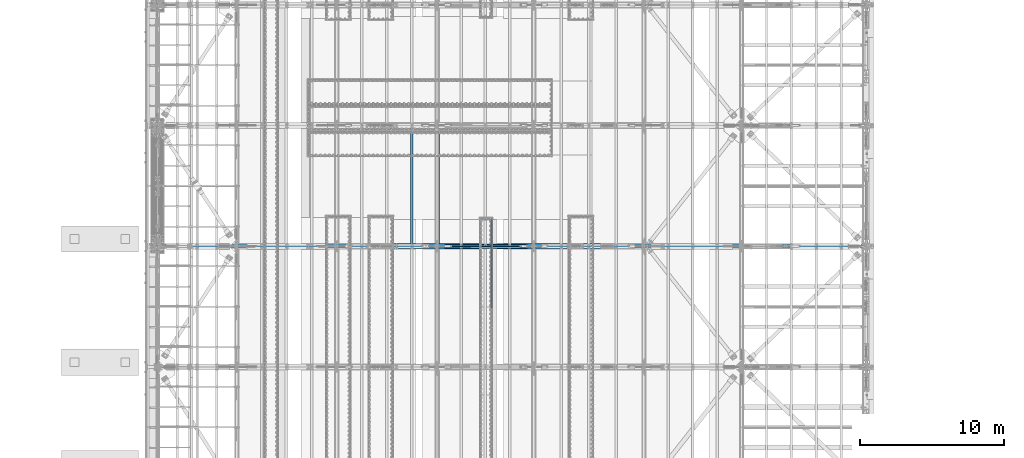
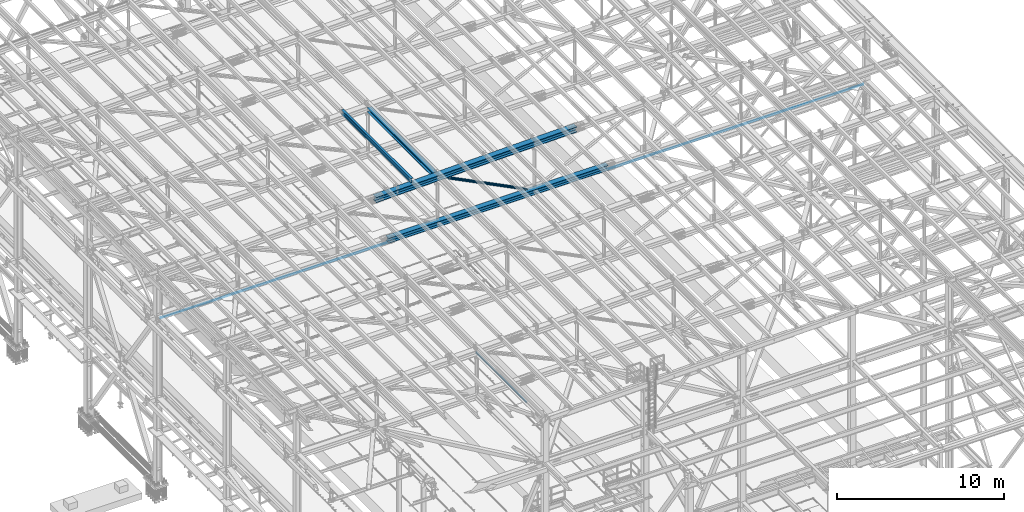
# One storey, part 1846 of 3843: 6 beams, 2 members, 8 elements without a shape of their own.
"""IFC2X3 building model written with IfcOpenShell, lengths in millimetres."""

from ifc_helpers import new_model, si_unit, frame, origin_with_axes, place, context, subcontext, project, spatial, faceted_brep, material, type_object, element, aggregate, save


model = new_model("IFC2X3")

# Units and contexts
model_context = context("Model", 3, precision=1e-05, world=origin_with_axes())
body_context = subcontext(model_context, "Body", "Model", "MODEL_VIEW")
ifc_project = project(units=[si_unit("LENGTHUNIT", "METRE", prefix="MILLI"), si_unit("AREAUNIT", "SQUARE_METRE"), si_unit("VOLUMEUNIT", "CUBIC_METRE"), si_unit("MASSUNIT", "GRAM", prefix="KILO"), si_unit("TIMEUNIT", "SECOND"), si_unit("PLANEANGLEUNIT", "RADIAN"), si_unit("SOLIDANGLEUNIT", "STERADIAN"), si_unit("THERMODYNAMICTEMPERATUREUNIT", "DEGREE_CELSIUS"), si_unit("LUMINOUSINTENSITYUNIT", "LUMEN")], contexts=[model_context])

# Site, building, storey
site_placement = place(None, origin_with_axes())
site = spatial("IfcSite", under=ifc_project, at=site_placement, CompositionType="ELEMENT")
building_placement = place(site_placement, origin_with_axes())
building = spatial("IfcBuilding", under=site, at=building_placement, Name="Undefined", CompositionType="ELEMENT")
storey_placement = place(building_placement, origin_with_axes())
storey = spatial("IfcBuildingStorey", under=building, at=storey_placement, Name="Undefined", CompositionType="ELEMENT", Elevation=0.0)

# Assembly, beam
assembly_1_placement = place(storey_placement, origin_with_axes())
assembly_1 = element("IfcElementAssembly", 1, at=assembly_1_placement, inside=storey, Name="EMBED_ANGLE", AssemblyPlace="NOTDEFINED", PredefinedType="RIGID_FRAME")
ifc_material_1 = material(Name="STEEL/A36")
beam_type_1 = type_object("IfcBeamType", Name="L3-1/2X3-1/2X5/16", PredefinedType="NOTDEFINED")
beam_1_placement = place(assembly_1_placement, frame((59697.1121396485, 52488.972265625, 30410.1500000001), z_axis=(0.0, 0.0, -1.0), x_axis=(0.0, -1.0, 0.0)))
beam_1 = element("IfcBeam", 2, at=beam_1_placement, type_object=beam_type_1, material=ifc_material_1, Name="EMBED_ANGLE", ObjectType="L3-1/2X3-1/2X5/16", context=body_context, shape_type="Brep", body=[
    faceted_brep([(88.8999999971129, 44.4500000000007, -44.4499999999971), (88.8999999965163, 44.4499999999971, 44.4500000000007), (6184.90000000001, 44.4499999999971, 44.4500000000007), (6184.90000000001, 44.4499999999971, -44.4500000000007), (80.9624999965163, 36.5124999999971, 44.4500000000007), (6184.90000000001, 36.5124999999971, 44.4500000000007), (80.9624999971129, 36.5125000000007, -36.5124999999971), (6184.90000000001, 36.5124999999971, -36.5125000000007), (3.63797880709171e-12, -44.4499999999971, -36.5125000000007), (6184.89999999999, -44.4499999999971, -36.5125000000007), (3.63797880709171e-12, -44.4499999999971, -44.4500000000007), (6184.89999999999, -44.4499999999971, -44.4500000000007)], [[[0, 1, 2, 3]], [[1, 4, 5, 2]], [[4, 6, 7, 5]], [[6, 8, 9, 7]], [[8, 10, 11, 9]], [[10, 0, 3, 11]], [[5, 7, 9, 11, 3, 2]], [[10, 8, 6, 4, 1, 0]]]),
])
aggregate(assembly_1, [beam_1])

assembly_2_placement = place(storey_placement, origin_with_axes())
assembly_2 = element("IfcElementAssembly", 3, at=assembly_2_placement, inside=storey, Name="BEAM", AssemblyPlace="NOTDEFINED", PredefinedType="RIGID_FRAME")
ifc_material_2 = material(Name="STEEL/A992")
beam_type_2 = type_object("IfcBeamType", Name="W12X26", PredefinedType="NOTDEFINED")
beam_2_placement = place(assembly_2_placement, frame((54193.9592622954, 50558.6608861599, 46024.798146897), z_axis=(-0.0211520976762986, -0.000251414999933331, 0.999776237742421), x_axis=(0.0, 0.999999968381168, 0.000251471000096098)))
beam_2 = element("IfcBeam", 4, at=beam_2_placement, type_object=beam_type_2, material=ifc_material_2, Name="BEAM", ObjectType="W12X26", context=body_context, shape_type="Brep", body=[
    faceted_brep([(12.6995182858154, 82.5499999993117, -155.575000000114), (12.7019560247718, 82.5499999999447, -146.050000000359), (8343.90221940629, 82.5500000000393, -146.050000005314), (8343.89983598545, 82.549999998897, -155.574999980701), (12.7023782314136, 3.1750000000975, -146.050000000454), (8343.90264161295, 3.17500000019209, -146.050000005402), (12.7758164776169, 3.17499999987922, 146.050000000439), (8343.97607985915, 3.17499999998108, 146.049999995492), (12.7753942709678, 82.5499999997337, 146.050000000534), (8343.9756576525, 82.5499999998356, 146.049999995586), (12.7777889963836, 82.5499999997337, 155.575000000565), (8343.97805237792, 82.5499999998283, 155.574999995617), (12.7786671862123, -82.549999999952, 155.575000000375), (8343.97893056775, -82.5499999998574, 155.574999995421), (12.7762724607965, -82.5499999999447, 146.050000000345), (8343.97653584233, -82.5499999998428, 146.04999999539), (12.7758502541474, -3.1750000000975, 146.050000000439), (8343.97611363568, -3.17499999999563, 146.049999995485), (12.7024120079514, -3.17499999989377, -146.050000000461), (8343.90267538947, -3.17499999979191, -146.050000005409), (12.7028342146004, -82.549999999741, -146.050000000556), (8343.90309759613, -82.5499999996391, -146.050000005511), (12.7004394891774, -82.5499999997337, -155.575000000586), (8343.90065697425, -82.5500000214379, -155.575000007513)], [[[0, 1, 2, 3]], [[1, 4, 5, 2]], [[4, 6, 7, 5]], [[6, 8, 9, 7]], [[8, 10, 11, 9]], [[10, 12, 13, 11]], [[12, 14, 15, 13]], [[14, 16, 17, 15]], [[16, 18, 19, 17]], [[18, 20, 21, 19]], [[20, 22, 23, 21]], [[22, 0, 3, 23]], [[5, 7, 9, 11, 13, 15, 17, 19, 21, 23, 3, 2]], [[22, 20, 18, 16, 14, 12, 10, 8, 6, 4, 1, 0]]]),
])
aggregate(assembly_2, [beam_2])

assembly_3_placement = place(storey_placement, origin_with_axes())
assembly_3 = element("IfcElementAssembly", 5, at=assembly_3_placement, inside=storey, Name="dummy", AssemblyPlace="NOTDEFINED", PredefinedType="RIGID_FRAME")
beam_type_3 = type_object("IfcBeamType", PredefinedType="NOTDEFINED")
beam_3_placement = place(assembly_3_placement, frame((36788.7249999692, 50558.7, 42063.6641279576), z_axis=(-0.00143273199948453, 0.0, 0.999998973638982), x_axis=(0.999998973638982, 0.0, 0.00143273199948273)))
beam_3 = element("IfcBeam", 6, at=beam_3_placement, type_object=beam_type_3, material=ifc_material_2, Name="dummy", context=body_context, shape_type="Brep", body=[
    faceted_brep([(0.0, -24.6059999999998, 0.0), (0.0, -21.3094210855197, -12.3029999999999), (48658.9063502672, -21.3094210855197, -12.3029998635975), (48658.9063502672, -24.6059999999998, 1.36402377393097e-07), (0.0, -12.3029999999999, -21.3094210855197), (48658.9063502673, -12.3029999999999, -21.3094209491173), (0.0, 0.0, -24.6059999999998), (48658.9063502673, 0.0, -24.6059998635974), (0.0, 12.3029999999999, -21.3094210855197), (48658.9063502673, 12.3029999999999, -21.3094209491173), (0.0, 21.3094210855197, -12.3029999999999), (48658.9063502672, 21.3094210855197, -12.3029998635975), (0.0, 24.6059999999998, 0.0), (48658.9063502672, 24.6059999999998, 1.36402377393097e-07), (0.0, 21.3094210855197, 12.3029999999999), (48658.9063502672, 21.3094210855197, 12.3030001364023), (0.0, 12.3029999999999, 21.3094210855197), (48658.9063502671, 12.3029999999999, 21.3094212219221), (0.0, 0.0, 24.6059999999998), (48658.9063502671, 0.0, 24.6060001363949), (0.0, -12.3029999999999, 21.3094210855197), (48658.9063502671, -12.3029999999999, 21.3094212219221), (0.0, -21.3094210855197, 12.3029999999999), (48658.9063502672, -21.3094210855197, 12.3030001364023)], [[[0, 1, 2, 3]], [[1, 4, 5, 2]], [[4, 6, 7, 5]], [[6, 8, 9, 7]], [[8, 10, 11, 9]], [[10, 12, 13, 11]], [[12, 14, 15, 13]], [[14, 16, 17, 15]], [[16, 18, 19, 17]], [[18, 20, 21, 19]], [[20, 22, 23, 21]], [[22, 0, 3, 23]], [[5, 7, 9, 11, 13, 15, 17, 19, 21, 23, 3, 2]], [[22, 20, 18, 16, 14, 12, 10, 8, 6, 4, 1, 0]]]),
])
aggregate(assembly_3, [beam_3])

assembly_4_placement = place(storey_placement, origin_with_axes())
assembly_4 = element("IfcElementAssembly", 7, at=assembly_4_placement, inside=storey, Name="BEAM", AssemblyPlace="NOTDEFINED", PredefinedType="RIGID_FRAME")
beam_type_4 = type_object("IfcBeamType", Name="W14X193", PredefinedType="NOTDEFINED")
beam_4_placement = place(assembly_4_placement, frame((51592.203019637, 50558.7, 45609.4388367108), z_axis=(-0.0230734749985422, 0.0, 0.999733771937055), x_axis=(0.999733771937055, 0.0, 0.0230734749985474)))
beam_4 = element("IfcBeam", 8, at=beam_4_placement, type_object=beam_type_4, material=ifc_material_2, Name="BEAM", ObjectType="W14X193", context=body_context, shape_type="Brep", body=[
    faceted_brep([(11138.0360007155, -200.025000000001, 163.291652715699), (11138.0360007155, -11.1125000000029, 163.291652715699), (12530.31678676, -11.1125000000029, 161.999149157797), (12530.31678676, -200.025000000001, 161.999149157797), (9745.75492082369, -200.025000000001, 164.214869607167), (9745.75492082369, -11.1125000000029, 164.214869607167), (8353.47364503366, -200.025000000001, 164.768799767946), (8353.47364503366, -11.1125000000029, 164.768799767946), (6961.19227129453, -200.025000000001, 164.95344315705), (6961.19227129453, -11.1125000000029, 164.95344315705), (5568.91089755539, -200.025000000001, 164.768799763304), (5568.91089755539, -11.1125000000029, 164.768799763304), (4176.62962176537, -200.025000000001, 164.214869597883), (4176.62962176537, -11.1125000000029, 164.214869597883), (2784.34854187357, -200.025000000001, 163.291652701781), (2784.34854187357, -11.1125000000029, 163.291652701781), (1392.06770966276, -200.024999999994, 161.999149022595), (1392.06770966276, -11.1125000000029, 161.999149022595), (6.1373568522904, -200.024999999994, 160.344938192073), (6.1373568522904, -11.1125000000029, 160.344938192073), (11138.0360007155, 11.1125000000029, 163.291652715699), (11138.0360007155, 200.025000000001, 163.291652715699), (12530.31678676, 200.025000000001, 161.999149157797), (12530.31678676, 11.1125000000029, 161.999149157797), (9745.75492082369, 11.1125000000029, 164.214869607167), (9745.75492082369, 200.025000000001, 164.214869607167), (8353.47364503366, 11.1125000000029, 164.768799767946), (8353.47364503366, 200.025000000001, 164.768799767946), (6961.19227129453, 11.1125000000029, 164.95344315705), (6961.19227129453, 200.025000000001, 164.95344315705), (5568.91089755539, 11.1125000000029, 164.768799763304), (5568.91089755539, 200.025000000001, 164.768799763304), (4176.62962176537, 11.1125000000029, 164.214869597883), (4176.62962176537, 200.025000000001, 164.214869597883), (2784.34854187357, 11.1125000000029, 163.291652701781), (2784.34854187357, 200.025000000001, 163.291652701781), (1392.06770966276, 11.1125000000029, 161.999149022595), (1392.06770966276, 200.024999999994, 161.999149022595), (6.1373568522904, 11.1125000000029, 160.344938192073), (6.1373568522904, 200.024999999994, 160.344938192073), (11137.7808345657, 200.025000000001, -157.383245765268), (11137.7808345657, 11.1125000000029, -157.383245765268), (12529.9765652546, 11.1125000000029, -158.675670363271), (12529.9765652546, 200.025000000001, -158.675670363271), (9745.58481004733, 200.025000000001, -156.460085273728), (9745.58481004733, 11.1125000000029, -156.460085273728), (8353.38858964276, 200.025000000001, -155.906188952918), (8353.38858964276, 11.1125000000029, -155.906188952918), (6961.19227129506, 200.025000000001, -155.72155684379), (6961.19227129506, 11.1125000000029, -155.72155684379), (5568.99595294736, 200.025000000001, -155.906188957546), (5568.99595294736, 11.1125000000029, -155.906188957546), (4176.7997325428, 200.025000000001, -156.460085283012), (4176.7997325428, 11.1125000000029, -156.460085283012), (2784.60370802448, 200.025000000001, -157.383245779187), (2784.60370802448, 11.1125000000029, -157.383245779187), (1392.40793115649, 200.024999999994, -158.675670497403), (1392.40793115649, 11.1125000000029, -158.675670497403), (6.56263357216085, 200.024999999994, -160.329779808199), (6.56263357216085, 11.1125000000029, -160.329779808199), (11137.7517809941, -200.025000000001, -193.895734206162), (11137.7517809941, 200.025000000001, -193.895734206162), (12529.9378271624, 200.025000000001, -195.188149813694), (12529.9378271624, -200.025000000001, -195.188149813694), (9745.56544099854, -200.025000000001, -192.972580136411), (9745.56544099854, 200.025000000001, -192.972580136411), (8353.37890511805, -200.025000000001, -192.418687668658), (8353.37890511805, 200.025000000001, -192.418687668658), (6961.19227129512, -200.025000000001, -192.234056843889), (6961.19227129512, 200.025000000001, -192.234056843889), (5569.0056374722, -200.025000000001, -192.418687673293), (5569.0056374722, 200.025000000001, -192.418687673293), (4176.8191015917, -200.025000000001, -192.972580145688), (4176.8191015917, 200.025000000001, -192.972580145688), (2784.63276159612, -200.025000000001, -193.895734220081), (2784.63276159612, 200.025000000001, -193.895734220081), (1392.44666924737, -200.024999999994, -195.188149947709), (1392.44666924737, 200.024999999994, -195.188149947709), (6.61105616897839, -200.024999999994, -196.842247699315), (6.61105616897839, 200.024999999994, -196.842247699315), (11137.7808345657, -11.1125000000029, -157.383245765268), (11137.7808345657, -200.025000000001, -157.383245765268), (12529.9765652546, -200.025000000001, -158.675670363271), (12529.9765652546, -11.1125000000029, -158.675670363271), (9745.58481004733, -11.1125000000029, -156.460085273728), (9745.58481004733, -200.025000000001, -156.460085273728), (8353.38858964276, -11.1125000000029, -155.906188952918), (8353.38858964276, -200.025000000001, -155.906188952918), (6961.19227129506, -11.1125000000029, -155.72155684379), (6961.19227129506, -200.025000000001, -155.72155684379), (5568.99595294736, -11.1125000000029, -155.906188957546), (5568.99595294736, -200.025000000001, -155.906188957546), (4176.7997325428, -11.1125000000029, -156.460085283012), (4176.7997325428, -200.025000000001, -156.460085283012), (2784.60370802448, -11.1125000000029, -157.383245779187), (2784.60370802448, -200.025000000001, -157.383245779187), (1392.40793115649, -11.1125000000029, -158.675670497403), (1392.40793115649, -200.024999999994, -158.675670497403), (6.56263357216085, -11.1125000000029, -160.329779808199), (6.56263357216085, -200.024999999994, -160.329779808199), (6.08893425547285, -200.024999999994, 196.857406083196), (6.08893425547285, 200.024999999994, 196.857406083196), (1392.02897157188, -200.024999999994, 198.511628472894), (1392.02897157188, 200.024999999994, 198.511628472894), (2784.31948830192, -200.025000000001, 199.804141142682), (2784.31948830192, 200.025000000001, 199.804141142682), (4176.61025271645, -200.025000000001, 200.727364460559), (4176.61025271645, 200.025000000001, 200.727364460559), (5568.90121303056, -200.025000000001, 201.281298479051), (5568.90121303056, 200.025000000001, 201.281298479051), (6961.19227129447, -200.025000000001, 201.465943157142), (6961.19227129447, 200.025000000001, 201.465943157142), (8353.48332955838, -200.025000000001, 201.281298483686), (8353.48332955838, 200.025000000001, 201.281298483686), (9745.77428987249, -200.025000000001, 200.727364469843), (9745.77428987249, 200.025000000001, 200.727364469843), (11138.065054287, -200.025000000001, 199.804141156601), (11138.065054287, 200.025000000001, 199.804141156601), (12530.3555248522, -200.025000000001, 198.511628608219), (12530.3555248522, 200.025000000001, 198.511628608219), (13916.2956101391, -200.025000000001, 196.857406104224), (13916.2956101391, 200.025000000001, 196.857406104224), (13916.2472005267, 200.025000000001, 160.344938197486), (13916.2472005267, 11.1125000000029, 160.344938197486), (13915.8220378443, 11.1125000000029, -160.329779939973), (13915.8220378443, 200.025000000001, -160.329779939973), (13915.773628232, 200.025000000001, -196.842247846711), (13915.773628232, -200.025000000001, -196.842247846711), (13915.8220378443, -200.025000000001, -160.329779939973), (13915.8220378443, -11.1125000000029, -160.329779939973), (13916.2472005267, -11.1125000000029, 160.344938197486), (13916.2472005267, -200.025000000001, 160.344938197486)], [[[0, 1, 2, 3]], [[4, 5, 1, 0]], [[6, 7, 5, 4]], [[8, 9, 7, 6]], [[10, 11, 9, 8]], [[12, 13, 11, 10]], [[14, 15, 13, 12]], [[16, 17, 15, 14]], [[17, 16, 18, 19]], [[20, 21, 22, 23]], [[24, 25, 21, 20]], [[26, 27, 25, 24]], [[28, 29, 27, 26]], [[30, 31, 29, 28]], [[32, 33, 31, 30]], [[34, 35, 33, 32]], [[36, 37, 35, 34]], [[37, 36, 38, 39]], [[40, 41, 42, 43]], [[44, 45, 41, 40]], [[46, 47, 45, 44]], [[48, 49, 47, 46]], [[50, 51, 49, 48]], [[52, 53, 51, 50]], [[54, 55, 53, 52]], [[56, 57, 55, 54]], [[57, 56, 58, 59]], [[60, 61, 62, 63]], [[64, 65, 61, 60]], [[66, 67, 65, 64]], [[68, 69, 67, 66]], [[70, 71, 69, 68]], [[72, 73, 71, 70]], [[74, 75, 73, 72]], [[76, 77, 75, 74]], [[77, 76, 78, 79]], [[80, 81, 82, 83]], [[84, 85, 81, 80]], [[86, 87, 85, 84]], [[88, 89, 87, 86]], [[90, 91, 89, 88]], [[92, 93, 91, 90]], [[94, 95, 93, 92]], [[96, 97, 95, 94]], [[97, 96, 98, 99]], [[19, 18, 100, 101, 39, 38, 59, 58, 79, 78, 99, 98]], [[102, 103, 101, 100]], [[103, 102, 104, 105]], [[105, 104, 106, 107]], [[107, 106, 108, 109]], [[109, 108, 110, 111]], [[111, 110, 112, 113]], [[113, 112, 114, 115]], [[115, 114, 116, 117]], [[117, 116, 118, 119]], [[119, 118, 120, 121]], [[22, 21, 25, 27, 29, 31, 33, 35, 37, 39, 101, 103, 105, 107, 109, 111, 113, 115, 117, 119, 121, 122]], [[23, 22, 122, 123]], [[42, 41, 45, 47, 49, 51, 53, 55, 57, 59, 38, 36, 34, 32, 30, 28, 26, 24, 20, 23, 123, 124]], [[43, 42, 124, 125]], [[62, 61, 65, 67, 69, 71, 73, 75, 77, 79, 58, 56, 54, 52, 50, 48, 46, 44, 40, 43, 125, 126]], [[63, 62, 126, 127]], [[82, 81, 85, 87, 89, 91, 93, 95, 97, 99, 78, 76, 74, 72, 70, 68, 66, 64, 60, 63, 127, 128]], [[83, 82, 128, 129]], [[2, 1, 5, 7, 9, 11, 13, 15, 17, 19, 98, 96, 94, 92, 90, 88, 86, 84, 80, 83, 129, 130]], [[3, 2, 130, 131]], [[118, 116, 114, 112, 110, 108, 106, 104, 102, 100, 18, 16, 14, 12, 10, 8, 6, 4, 0, 3, 131, 120]], [[130, 129, 128, 127, 126, 125, 124, 123, 122, 121, 120, 131]]]),
])
aggregate(assembly_4, [beam_4])

assembly_5_placement = place(storey_placement, origin_with_axes())
assembly_5 = element("IfcElementAssembly", 9, at=assembly_5_placement, inside=storey, Name="BEAM", AssemblyPlace="NOTDEFINED", PredefinedType="RIGID_FRAME")
beam_type_5 = type_object("IfcBeamType", Name="W14X120", PredefinedType="NOTDEFINED")
beam_5_placement = place(assembly_5_placement, frame((52463.7000420747, 50558.7, 42319.5670656356), z_axis=(-0.00162579500064021, 0.0, 0.999998678394435), x_axis=(0.999998678394435, 0.0, 0.00162579500064107)))
beam_5 = element("IfcBeam", 10, at=beam_5_placement, type_object=beam_type_5, material=ifc_material_2, Name="BEAM", ObjectType="W14X120", context=body_context, shape_type="Brep", body=[
    faceted_brep([(12202.3170478339, -185.737500000003, 163.884636835646), (12202.3170478339, -7.14375000000291, 163.884636835646), (13727.6354236228, -7.14375000000291, 162.332690249139), (13727.6354236228, -185.737500000003, 162.332690249139), (10676.9982853416, -185.737500000003, 164.99317020653), (10676.9982853416, -7.14375000000291, 164.99317020653), (9151.67926504687, -185.737500000003, 165.658290269588), (9151.67926504687, -7.14375000000291, 165.658290269588), (7626.360115851, -185.737500000003, 165.879996966149), (7626.360115851, -7.14375000000291, 165.879996966149), (6101.04096665512, -185.737500000003, 165.658290279447), (6101.04096665512, -7.14375000000291, 165.658290279447), (4575.72194636041, -185.737500000003, 164.993170226247), (4575.72194636041, -7.14375000000291, 164.993170226247), (3050.40318386804, -185.737500000003, 163.884636865223), (3050.40318386804, -7.14375000000291, 163.884636865223), (1525.08480807913, -185.737500000003, 162.332690288575), (1525.08480807913, -7.14375000000291, 162.332690288575), (6.11694251566951, -185.737500000003, 160.345637435974), (6.11694251566951, -7.14375000000291, 160.345637435974), (12202.3170478339, 7.14375000000291, 163.884636835646), (12202.3170478339, 185.737500000003, 163.884636835646), (13727.6354236228, 185.737500000003, 162.332690249139), (13727.6354236228, 7.14375000000291, 162.332690249139), (10676.9982853416, 7.14375000000291, 164.99317020653), (10676.9982853416, 185.737500000003, 164.99317020653), (9151.67926504687, 7.14375000000291, 165.658290269588), (9151.67926504687, 185.737500000003, 165.658290269588), (7626.360115851, 7.14375000000291, 165.879996966149), (7626.360115851, 185.737500000003, 165.879996966149), (6101.04096665512, 7.14375000000291, 165.658290279447), (6101.04096665512, 185.737500000003, 165.658290279447), (4575.72194636041, 7.14375000000291, 164.993170226247), (4575.72194636041, 185.737500000003, 164.993170226247), (3050.40318386804, 7.14375000000291, 163.884636865223), (3050.40318386804, 185.737500000003, 163.884636865223), (1525.08480807913, 7.14375000000291, 162.332690288575), (1525.08480807913, 185.737500000003, 162.332690288575), (6.11694251566951, 7.14375000000291, 160.345637435974), (6.11694251566951, 185.737500000003, 160.345637435974), (12202.037385243, 185.737500000003, -156.790241215553), (12202.037385243, 7.14375000000291, -156.790241215553), (13727.2625402054, 7.14375000000291, -158.342092953826), (13727.2625402054, 185.737500000003, -158.342092953826), (10676.8118436008, 185.737500000003, -155.68177559341), (10676.8118436008, 7.14375000000291, -155.68177559341), (9151.58604417203, 185.737500000003, -155.016696179591), (9151.58604417203, 7.14375000000291, -155.016696179591), (7626.36011584996, 185.737500000003, -154.795003032777), (7626.36011584996, 7.14375000000291, -154.795003032777), (6101.13418752788, 185.737500000003, -155.016696169732), (6101.13418752788, 7.14375000000291, -155.016696169732), (4575.90838809909, 185.737500000003, -155.681775573692), (4575.90838809909, 7.14375000000291, -155.681775573692), (3050.68284645689, 185.737500000003, -156.790241185976), (3050.68284645689, 7.14375000000291, -156.790241185976), (1525.45769149451, 185.737500000003, -158.342092914398), (1525.45769149451, 7.14375000000291, -158.342092914398), (6.58304672223312, 185.737500000003, -160.3290238193), (6.58304672223312, 7.14375000000291, -160.3290238193), (12202.0166182189, -185.737500000003, -180.602732159947), (12202.0166182189, 185.737500000003, -180.602732159947), (13727.2348508427, 185.737500000003, -182.154576855035), (13727.2348508427, -185.737500000003, -182.154576855035), (10676.7979989171, -185.737500000003, -179.494271568648), (10676.7979989171, 185.737500000003, -179.494271568648), (9151.57912182983, -185.737500000003, -178.829195173341), (9151.57912182983, 185.737500000003, -178.829195173341), (7626.36011584988, -185.737500000003, -178.607503032697), (7626.36011584988, 185.737500000003, -178.607503032697), (6101.14110986992, -185.737500000003, -178.829195163482), (6101.14110986992, 185.737500000003, -178.829195163482), (4575.92223278266, -185.737500000003, -179.494271548931), (4575.92223278266, 185.737500000003, -179.494271548931), (3050.70361348081, -185.737500000003, -180.60273213037), (3050.70361348081, 185.737500000003, -180.60273213037), (1525.48538085704, -185.737500000003, -182.154576815607), (1525.48538085704, 185.737500000003, -182.154576815607), (6.61765842074965, -185.737500000003, -184.141498664983), (6.61765842074965, 185.737500000003, -184.141498664983), (12202.037385243, -7.14375000000291, -156.790241215553), (12202.037385243, -185.737500000003, -156.790241215553), (13727.2625402054, -185.737500000003, -158.342092953826), (13727.2625402054, -7.14375000000291, -158.342092953826), (10676.8118436008, -7.14375000000291, -155.68177559341), (10676.8118436008, -185.737500000003, -155.68177559341), (9151.58604417203, -7.14375000000291, -155.016696179591), (9151.58604417203, -185.737500000003, -155.016696179591), (7626.36011584996, -7.14375000000291, -154.795003032777), (7626.36011584996, -185.737500000003, -154.795003032777), (6101.13418752788, -7.14375000000291, -155.016696169732), (6101.13418752788, -185.737500000003, -155.016696169732), (4575.90838809909, -7.14375000000291, -155.681775573692), (4575.90838809909, -185.737500000003, -155.681775573692), (3050.68284645689, -7.14375000000291, -156.790241185976), (3050.68284645689, -185.737500000003, -156.790241185976), (1525.45769149451, -7.14375000000291, -158.342092914398), (1525.45769149451, -185.737500000003, -158.342092914398), (6.58304672223312, -7.14375000000291, -160.3290238193), (6.58304672223312, -185.737500000003, -160.3290238193), (6.08233081716025, -185.737500000003, 184.158112281657), (6.08233081716025, 185.737500000003, 184.158112281657), (1525.0571187166, -185.737500000003, 186.145174189784), (1525.0571187166, 185.737500000003, 186.145174189784), (3050.38241684411, -185.737500000003, 187.697127809617), (3050.38241684411, 185.737500000003, 187.697127809617), (4575.70810167684, -185.737500000003, 188.805666201486), (4575.70810167684, 185.737500000003, 188.805666201486), (6101.03404431308, -185.737500000003, 189.470789273197), (6101.03404431308, 185.737500000003, 189.470789273197), (7626.36011585107, -185.737500000003, 189.692496966061), (7626.36011585107, 185.737500000003, 189.692496966061), (9151.68618738905, -185.737500000003, 189.470789263331), (9151.68618738905, 185.737500000003, 189.470789263331), (10677.0121300253, -185.737500000003, 188.805666181768), (10677.0121300253, 185.737500000003, 188.805666181768), (12202.337814858, -185.737500000003, 187.697127780033), (12202.337814858, 185.737500000003, 187.697127780033), (13727.6631129855, -185.737500000003, 186.145174150355), (13727.6631129855, 185.737500000003, 186.145174150355), (15246.6378586869, -185.737500000003, 184.158112287609), (15246.6378586869, 185.737500000003, 184.158112287609), (15246.6032581907, 185.737500000003, 160.345637427265), (15246.6032581907, 7.14375000000291, 160.345637427265), (15246.137304843, 7.14375000000291, -160.329024025355), (15246.137304843, 185.737500000003, -160.329024025355), (15246.1027043468, 185.737500000003, -184.1414988857), (15246.1027043468, -185.737500000003, -184.1414988857), (15246.137304843, -185.737500000003, -160.329024025355), (15246.137304843, -7.14375000000291, -160.329024025355), (15246.6032581907, -7.14375000000291, 160.345637427265), (15246.6032581907, -185.737500000003, 160.345637427265)], [[[0, 1, 2, 3]], [[4, 5, 1, 0]], [[6, 7, 5, 4]], [[8, 9, 7, 6]], [[10, 11, 9, 8]], [[12, 13, 11, 10]], [[14, 15, 13, 12]], [[16, 17, 15, 14]], [[17, 16, 18, 19]], [[20, 21, 22, 23]], [[24, 25, 21, 20]], [[26, 27, 25, 24]], [[28, 29, 27, 26]], [[30, 31, 29, 28]], [[32, 33, 31, 30]], [[34, 35, 33, 32]], [[36, 37, 35, 34]], [[37, 36, 38, 39]], [[40, 41, 42, 43]], [[44, 45, 41, 40]], [[46, 47, 45, 44]], [[48, 49, 47, 46]], [[50, 51, 49, 48]], [[52, 53, 51, 50]], [[54, 55, 53, 52]], [[56, 57, 55, 54]], [[57, 56, 58, 59]], [[60, 61, 62, 63]], [[64, 65, 61, 60]], [[66, 67, 65, 64]], [[68, 69, 67, 66]], [[70, 71, 69, 68]], [[72, 73, 71, 70]], [[74, 75, 73, 72]], [[76, 77, 75, 74]], [[77, 76, 78, 79]], [[80, 81, 82, 83]], [[84, 85, 81, 80]], [[86, 87, 85, 84]], [[88, 89, 87, 86]], [[90, 91, 89, 88]], [[92, 93, 91, 90]], [[94, 95, 93, 92]], [[96, 97, 95, 94]], [[97, 96, 98, 99]], [[19, 18, 100, 101, 39, 38, 59, 58, 79, 78, 99, 98]], [[102, 103, 101, 100]], [[103, 102, 104, 105]], [[105, 104, 106, 107]], [[107, 106, 108, 109]], [[109, 108, 110, 111]], [[111, 110, 112, 113]], [[113, 112, 114, 115]], [[115, 114, 116, 117]], [[117, 116, 118, 119]], [[119, 118, 120, 121]], [[22, 21, 25, 27, 29, 31, 33, 35, 37, 39, 101, 103, 105, 107, 109, 111, 113, 115, 117, 119, 121, 122]], [[23, 22, 122, 123]], [[42, 41, 45, 47, 49, 51, 53, 55, 57, 59, 38, 36, 34, 32, 30, 28, 26, 24, 20, 23, 123, 124]], [[43, 42, 124, 125]], [[62, 61, 65, 67, 69, 71, 73, 75, 77, 79, 58, 56, 54, 52, 50, 48, 46, 44, 40, 43, 125, 126]], [[63, 62, 126, 127]], [[82, 81, 85, 87, 89, 91, 93, 95, 97, 99, 78, 76, 74, 72, 70, 68, 66, 64, 60, 63, 127, 128]], [[83, 82, 128, 129]], [[2, 1, 5, 7, 9, 11, 13, 15, 17, 19, 98, 96, 94, 92, 90, 88, 86, 84, 80, 83, 129, 130]], [[3, 2, 130, 131]], [[118, 116, 114, 112, 110, 108, 106, 104, 102, 100, 18, 16, 14, 12, 10, 8, 6, 4, 0, 3, 131, 120]], [[130, 129, 128, 127, 126, 125, 124, 123, 122, 121, 120, 131]]]),
])
aggregate(assembly_5, [beam_5])

# Assembly, member
assembly_6_placement = place(storey_placement, origin_with_axes())
assembly_6 = element("IfcElementAssembly", 11, at=assembly_6_placement, inside=storey, Name="ANGLE", AssemblyPlace="NOTDEFINED", PredefinedType="RIGID_FRAME")
ifc_material_3 = material(Name="STEEL/A572-50")
member_type = type_object("IfcMemberType", Name="L5X5X3/8", PredefinedType="NOTDEFINED")
member_1_placement = place(assembly_6_placement, frame((55930.7999998517, 50631.725, 45713.5153476111), z_axis=(-0.449315652995785, 0.0, -0.893373070991605), x_axis=(0.893373070991606, 0.0, -0.449315652995782)))
member_1 = element("IfcMember", 12, at=member_1_placement, type_object=member_type, material=ifc_material_3, Name="ANGLE", ObjectType="L5X5X3/8", context=body_context, shape_type="Brep", body=[
    faceted_brep([(592.623068832821, 63.5, -63.500000000844), (592.623068832818, 63.5, 63.4999999988941), (6914.71997289444, 63.5, 63.4999999885767), (6914.71997289444, 63.5, -63.5000000111613), (592.623068832818, 53.9749999999985, 63.4999999988941), (6914.71997289444, 53.9749999999985, 63.4999999885767), (592.623068832818, 53.9749999999985, -53.9750000008644), (6914.71997289444, 53.9749999999985, -53.9750000111817), (592.623068832818, -63.5, -53.9750000008644), (6914.71997289444, -63.5, -53.9750000111817), (592.623068832821, -63.5, -63.500000000844), (6914.71997289444, -63.5, -63.5000000111613)], [[[0, 1, 2, 3]], [[1, 4, 5, 2]], [[4, 6, 7, 5]], [[6, 8, 9, 7]], [[8, 10, 11, 9]], [[10, 0, 3, 11]], [[5, 7, 9, 11, 3, 2]], [[10, 8, 6, 4, 1, 0]]]),
])
aggregate(assembly_6, [member_1])

assembly_7_placement = place(storey_placement, origin_with_axes())
assembly_7 = element("IfcElementAssembly", 13, at=assembly_7_placement, inside=storey, Name="ANGLE", AssemblyPlace="NOTDEFINED", PredefinedType="RIGID_FRAME")
member_2_placement = place(assembly_7_placement, frame((62636.4000001751, 50485.675, 42340.9813604837), z_axis=(-0.449315652995785, 0.0, -0.893373070991605), x_axis=(-0.893373070991608, 0.0, 0.449315652995778)))
member_2 = element("IfcMember", 14, at=member_2_placement, type_object=member_type, material=ifc_material_3, Name="ANGLE", ObjectType="L5X5X3/8", context=body_context, shape_type="Brep", body=[
    faceted_brep([(591.214802881346, 63.5, -63.4999999989086), (591.214802881346, 63.5, 63.5000000008295), (6913.31170694296, 63.5, 63.5000000111468), (6913.31170694296, 63.5, -63.4999999885913), (591.214802881346, 53.9749999999985, 63.5000000008295), (6913.31170694296, 53.9749999999985, 63.5000000111468), (591.214802881346, 53.9749999999985, -53.9749999989144), (6913.31170694296, 53.9749999999985, -53.9749999886117), (591.214802881346, -63.5, -53.9749999989144), (6913.31170694296, -63.5, -53.9749999886117), (591.214802881346, -63.5, -63.4999999989086), (6913.31170694296, -63.5, -63.4999999885913)], [[[0, 1, 2, 3]], [[1, 4, 5, 2]], [[4, 6, 7, 5]], [[6, 8, 9, 7]], [[8, 10, 11, 9]], [[10, 0, 3, 11]], [[5, 7, 9, 11, 3, 2]], [[10, 8, 6, 4, 1, 0]]]),
])
aggregate(assembly_7, [member_2])

# Assembly, beam
assembly_8_placement = place(storey_placement, origin_with_axes())
assembly_8 = element("IfcElementAssembly", 15, at=assembly_8_placement, inside=storey, Name="BEAM", AssemblyPlace="NOTDEFINED", PredefinedType="RIGID_FRAME")
beam_type_6 = type_object("IfcBeamType", Name="W12X65", PredefinedType="NOTDEFINED")
beam_6_placement = place(assembly_8_placement, frame((55930.8, 50558.7000000007, 45713.5153479421), z_axis=(0.0, -0.000276146999967751, 0.999999961871416), x_axis=(0.0, 0.999999961871417, 0.000276146999964482)))
beam_6 = element("IfcBeam", 16, at=beam_6_placement, type_object=beam_type_6, material=ifc_material_2, Name="BEAM", ObjectType="W12X65", context=body_context, shape_type="Brep", body=[
    faceted_brep([(212.682484923535, 152.400000000001, -153.987499999901), (212.686868757322, 152.400000000001, -138.11249999985), (8143.83717120157, 152.400000000001, -138.112499981376), (8143.83278736778, 152.400000000001, -153.987499981413), (212.686868757322, 4.76249999999709, -138.11249999985), (8143.83717120157, 4.76249999999709, -138.112499981376), (212.763147465303, 4.76249999999709, 138.112500000854), (8143.91344990955, 4.76249999999709, 138.112500019335), (212.763147465303, 152.400000000001, 138.112500000854), (8143.91344990955, 152.400000000001, 138.112500019335), (212.767531299098, 152.400000000001, 153.987500000898), (8143.91783374333, 152.400000000001, 153.987500019372), (212.767531299098, -152.400000000001, 153.987500000898), (8143.91783374333, -152.400000000001, 153.987500019372), (212.763147465303, -152.400000000001, 138.112500000854), (8143.91344990955, -152.400000000001, 138.112500019335), (212.763147465303, -4.76249999999709, 138.112500000854), (8143.91344990955, -4.76249999999709, 138.112500019335), (212.686868757322, -4.76249999999709, -138.11249999985), (8143.83717120157, -4.76249999999709, -138.112499981376), (212.686868757322, -152.400000000001, -138.11249999985), (8143.83717120157, -152.400000000001, -138.112499981376), (212.682484923535, -152.400000000001, -153.987499999901), (8143.83278736778, -152.400000000001, -153.987499981413)], [[[0, 1, 2, 3]], [[1, 4, 5, 2]], [[4, 6, 7, 5]], [[6, 8, 9, 7]], [[8, 10, 11, 9]], [[10, 12, 13, 11]], [[12, 14, 15, 13]], [[14, 16, 17, 15]], [[16, 18, 19, 17]], [[18, 20, 21, 19]], [[20, 22, 23, 21]], [[22, 0, 3, 23]], [[5, 7, 9, 11, 13, 15, 17, 19, 21, 23, 3, 2]], [[22, 20, 18, 16, 14, 12, 10, 8, 6, 4, 1, 0]]]),
])
aggregate(assembly_8, [beam_6])

save(model, "model.ifc")
